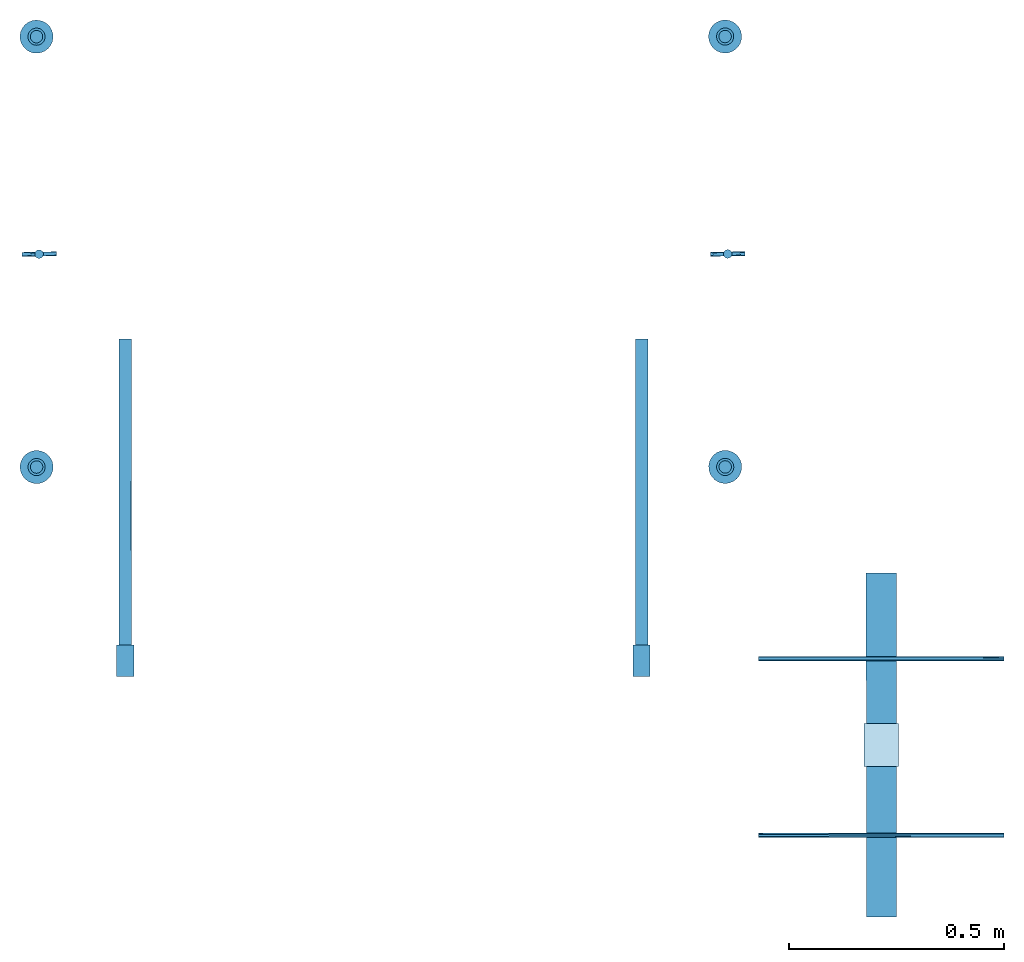
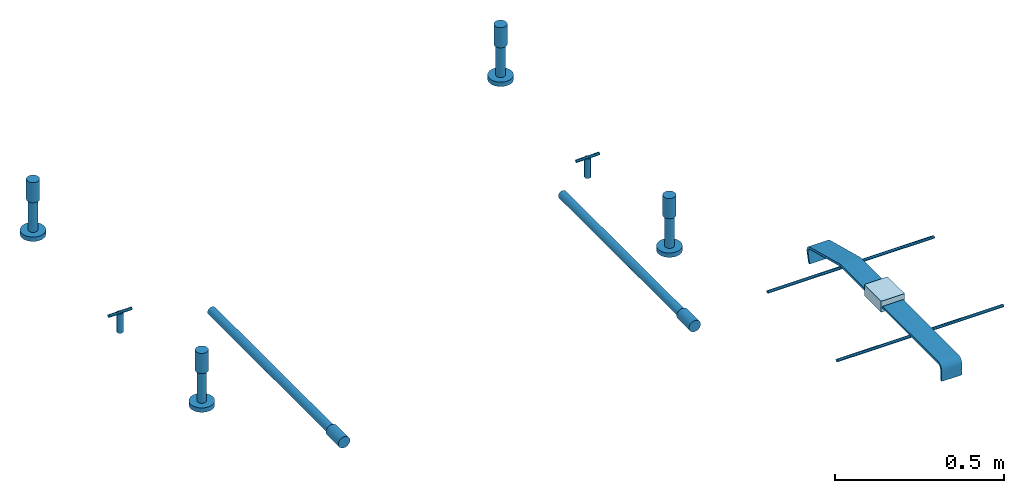
# One storey: 12 reinforcing bars, 6 columns, 4 discrete accessories, 2 beams, 1 plate, 9 elements without a shape of their own.
"""IFC2X3 building model written with IfcOpenShell, lengths in millimetres."""

from ifc_helpers import new_model, entity, si_unit, frame, frame_2d, origin_with_axes, origin_2d_with_axis, place, context, subcontext, project, spatial, polyline, circle_curve, parameter, trimmed, segment, composite_curve, circle, outline, extrude, source, transform, mapped, material, type_object, element, aggregate, save


model = new_model("IFC2X3")

# Units and contexts
model_context = context("Model", 3, precision=1e-05, world=origin_with_axes())
body_context = subcontext(model_context, "Body", "Model", "MODEL_VIEW")
ifc_project = project(units=[si_unit("LENGTHUNIT", "METRE", prefix="MILLI"), si_unit("AREAUNIT", "SQUARE_METRE"), si_unit("VOLUMEUNIT", "CUBIC_METRE"), si_unit("MASSUNIT", "GRAM", prefix="KILO"), si_unit("TIMEUNIT", "SECOND"), si_unit("PLANEANGLEUNIT", "RADIAN"), si_unit("SOLIDANGLEUNIT", "STERADIAN"), si_unit("THERMODYNAMICTEMPERATUREUNIT", "DEGREE_CELSIUS"), si_unit("LUMINOUSINTENSITYUNIT", "LUMEN")], contexts=[model_context])

# Site, building, storey
site_placement = place(None, origin_with_axes())
site = spatial("IfcSite", under=ifc_project, at=site_placement, CompositionType="ELEMENT")
building_placement = place(site_placement, origin_with_axes())
building = spatial("IfcBuilding", under=site, at=building_placement, Name="Undefined", CompositionType="ELEMENT")
storey_placement = place(building_placement, origin_with_axes())
storey = spatial("IfcBuildingStorey", under=building, at=storey_placement, Name="Undefined", CompositionType="ELEMENT", Elevation=0.0)

# Assembly, column
assembly_1_placement = place(storey_placement, origin_with_axes())
assembly_1 = element("IfcElementAssembly", 1, at=assembly_1_placement, inside=storey, Name="Steel Assembly", AssemblyPlace="NOTDEFINED", PredefinedType="RIGID_FRAME")
ifc_material_1 = material(Name="STEEL/Steel_Undefined")
column_type_1 = type_object("IfcColumnType", Name="D40", PredefinedType="NOTDEFINED")
column_1_placement = place(assembly_1_placement, frame((16512.5545735063, 4541.76865456294, 168.744955736245), z_axis=(0.0, 0.0, 1.0), x_axis=(-0.529843759894113, -0.848095271830512, 0.0)))
column_1 = element("IfcColumn", 2, at=column_1_placement, type_object=column_type_1, material=ifc_material_1, Name="PLA30", ObjectType="D40", context=body_context, shape_type="SweptSolid", body=[
    extrude(circle(Radius=20.0, at=origin_2d_with_axis()), frame((0.0, 0.0, 73.0000000000042), z_axis=(6.95326889399439e-11, -3.79999987217161e-07, -0.999999999999928), x_axis=(0.0, 1.0, 0.0)), (0.0, 0.0, 1.0), 73.0),
])

assembly_2_placement = place(storey_placement, origin_with_axes())
assembly_2 = element("IfcElementAssembly", 3, at=assembly_2_placement, inside=storey, Name="Steel Assembly", AssemblyPlace="NOTDEFINED", PredefinedType="RIGID_FRAME")
column_2_placement = place(assembly_2_placement, frame((16512.3715884973, 5541.76863781694, 180.406980387786), z_axis=(0.0, 0.0, 1.0), x_axis=(0.530154102006484, -0.847901308010371, 0.0)))
column_2 = element("IfcColumn", 4, at=column_2_placement, type_object=column_type_1, material=ifc_material_1, Name="PLA30", ObjectType="D40", context=body_context, shape_type="SweptSolid", body=[
    extrude(circle(Radius=20.0, at=origin_2d_with_axis()), frame((0.0, 0.0, 73.0000000000042), z_axis=(6.95326889399439e-11, -3.79999987217161e-07, -0.999999999999928), x_axis=(0.0, 1.0, 0.0)), (0.0, 0.0, 1.0), 73.0),
])

assembly_3_placement = place(storey_placement, origin_with_axes())
assembly_3 = element("IfcElementAssembly", 5, at=assembly_3_placement, inside=storey, Name="Steel Assembly", AssemblyPlace="NOTDEFINED", PredefinedType="RIGID_FRAME")
column_3_placement = place(assembly_3_placement, frame((14912.5546002998, 4541.47587857633, 168.744935248384), z_axis=(0.0, 0.0, 1.0), x_axis=(-0.530154102006485, 0.847901308010371, 0.0)))
column_3 = element("IfcColumn", 6, at=column_3_placement, type_object=column_type_1, material=ifc_material_1, Name="PLA30", ObjectType="D40", context=body_context, shape_type="SweptSolid", body=[
    extrude(circle(Radius=20.0, at=origin_2d_with_axis()), frame((0.0, 0.0, 73.0000000000042), z_axis=(6.95326889399439e-11, -3.79999987217161e-07, -0.999999999999928), x_axis=(0.0, 1.0, 0.0)), (0.0, 0.0, 1.0), 73.0),
])

assembly_4_placement = place(storey_placement, origin_with_axes())
assembly_4 = element("IfcElementAssembly", 7, at=assembly_4_placement, inside=storey, Name="Steel Assembly", AssemblyPlace="NOTDEFINED", PredefinedType="RIGID_FRAME")
column_4_placement = place(assembly_4_placement, frame((14912.3716152909, 5541.47586183033, 180.406959899928), z_axis=(0.0, 0.0, 1.0), x_axis=(0.529843759894112, 0.848095271830512, 0.0)))
column_4 = element("IfcColumn", 8, at=column_4_placement, type_object=column_type_1, material=ifc_material_1, Name="PLA30", ObjectType="D40", context=body_context, shape_type="SweptSolid", body=[
    extrude(circle(Radius=20.0, at=origin_2d_with_axis()), frame((0.0, 0.0, 73.0000000000042), z_axis=(6.95326889399439e-11, -3.79999987217161e-07, -0.999999999999928), x_axis=(0.0, 1.0, 0.0)), (0.0, 0.0, 1.0), 73.0),
])

assembly_5_placement = place(storey_placement, origin_with_axes())
assembly_5 = element("IfcElementAssembly", 9, at=assembly_5_placement, inside=storey, Name="Steel Assembly", AssemblyPlace="NOTDEFINED", PredefinedType="RIGID_FRAME")
ifc_material_2 = material(Name="STEEL/1.4305")
column_type_2 = type_object("IfcColumnType", Name="D20", PredefinedType="NOTDEFINED")
column_5_placement = place(assembly_5_placement, frame((14918.3528687996, 5036.27663697052, 4.99973108393383), z_axis=(0.0, 0.0, 1.0), x_axis=(-0.0185757400010389, 0.999827456056001, 0.0)))
column_5 = element("IfcColumn", 10, at=column_5_placement, type_object=column_type_2, material=ifc_material_2, Name="M16x70", ObjectType="D20", context=body_context, shape_type="SweptSolid", body=[
    extrude(circle(Radius=10.0, at=origin_2d_with_axis()), frame((0.0, 0.0, 70.0), z_axis=(6.95326889399439e-11, -3.79999987217161e-07, -0.999999999999928), x_axis=(0.0, 1.0, 0.0)), (0.0, 0.0, 1.0), 70.0),
])

assembly_6_placement = place(storey_placement, origin_with_axes())
assembly_6 = element("IfcElementAssembly", 11, at=assembly_6_placement, inside=storey, Name="Steel Assembly", AssemblyPlace="NOTDEFINED", PredefinedType="RIGID_FRAME")
column_6_placement = place(assembly_6_placement, frame((16518.352842022, 5036.5694137126, 4.99973107646505), z_axis=(0.0, 0.0, 1.0), x_axis=(-0.0185757400010389, 0.999827456056001, 0.0)))
column_6 = element("IfcColumn", 12, at=column_6_placement, type_object=column_type_2, material=ifc_material_2, Name="M16x70", ObjectType="D20", context=body_context, shape_type="SweptSolid", body=[
    extrude(circle(Radius=10.0, at=origin_2d_with_axis()), frame((0.0, 0.0, 70.0), z_axis=(6.95326889399439e-11, -3.79999987217161e-07, -0.999999999999928), x_axis=(0.0, 1.0, 0.0)), (0.0, 0.0, 1.0), 70.0),
])

# Assembly, beam
assembly_7_placement = place(storey_placement, origin_with_axes())
assembly_7 = element("IfcElementAssembly", 13, at=assembly_7_placement, inside=storey, Name="Steel Assembly", AssemblyPlace="NOTDEFINED", PredefinedType="RIGID_FRAME")
beam_type = type_object("IfcBeamType", Name="D40", PredefinedType="NOTDEFINED")
beam_1_placement = place(assembly_7_placement, frame((16318.3244750707, 4127.76566994442, 129.998808840351), z_axis=(-2.6939999552269e-06, 1.19564911619818e-06, 0.999999999995656), x_axis=(0.000130249999940337, -0.999999991516754, 1.19599999948291e-06)))
beam_1 = element("IfcBeam", 14, at=beam_1_placement, type_object=beam_type, material=ifc_material_1, Name="PLA30P RST", ObjectType="D40", context=body_context, shape_type="SweptSolid", body=[
    extrude(circle(Radius=20.0, at=origin_2d_with_axis()), frame((72.9999999999711, -1.81899029789767e-12, 0.0), z_axis=(-1.0, 1.22513946707428e-20, 0.0), x_axis=(1.20588191077635e-20, -1.0, -4.2351647362715e-22)), (0.0, 0.0, 1.0), 73.0),
])

assembly_8_placement = place(storey_placement, origin_with_axes())
assembly_8 = element("IfcElementAssembly", 15, at=assembly_8_placement, inside=storey, Name="Steel Assembly", AssemblyPlace="NOTDEFINED", PredefinedType="RIGID_FRAME")
beam_2_placement = place(assembly_8_placement, frame((15118.3244850687, 4127.60936877322, 129.995575973906), z_axis=(-2.6939999552269e-06, 1.19564911619818e-06, 0.999999999995656), x_axis=(0.000130249999940337, -0.999999991516754, 1.19599999948291e-06)))
beam_2 = element("IfcBeam", 16, at=beam_2_placement, type_object=beam_type, material=ifc_material_1, Name="PLA30P RST", ObjectType="D40", context=body_context, shape_type="SweptSolid", body=[
    extrude(circle(Radius=20.0, at=origin_2d_with_axis()), frame((72.9999999999711, -1.81899029789767e-12, 0.0), z_axis=(-1.0, 1.22513946707428e-20, 0.0), x_axis=(1.20588191077635e-20, -1.0, -4.2351647362715e-22)), (0.0, 0.0, 1.0), 73.0),
])

# Assembly, plate
assembly_9_placement = place(storey_placement, origin_with_axes())
assembly_9 = element("IfcElementAssembly", 17, at=assembly_9_placement, inside=storey, Name="Steel Assembly", AssemblyPlace="NOTDEFINED", PredefinedType="RIGID_FRAME")
plate_type = type_object("IfcPlateType", Name="PL80X40", PredefinedType="NOTDEFINED")
plate_placement = place(assembly_9_placement, frame((16875.2878480208, 3945.99448057464, 125.299789938123), z_axis=(0.999999983258245, 0.000182985000042784, -6.95343011720966e-11), x_axis=(0.0, 0.0, 1.0)))
plate = element("IfcPlate", 18, at=plate_placement, type_object=plate_type, material=ifc_material_1, Name="PS170", ObjectType="PL80X40", context=body_context, shape_type="SweptSolid", body=[
    extrude(outline(polyline([(0.0, 0.0), (40.0000000000003, -7.27595761418343e-12), (39.9999999999937, 99.9999999999027), (-6.60804744256893e-12, 99.9999999999091), (0.0, 0.0)])), frame((5.16987882845642e-25, -1.26000840385288e-18, -40.0), z_axis=(0.0, 0.0, 1.0), x_axis=(1.0, 0.0, 0.0)), (0.0, 0.0, 1.0), 80.0),
])

# Reinforcing bar
ifc_material_3 = material(Name="Undefined")
shared_shape_1 = source(origin_with_axes(), body_context, "Body", "AdvancedSweptSolid", [
    entity("IfcSweptDiskSolid", entity("IfcTrimmedCurve", entity("IfcLine", entity("IfcCartesianPoint", [0.0, 0.0, 0.0]), entity("IfcVector", entity("IfcDirection", [1.0, 0.0, 0.0]), 1.0)), [entity("IfcParameterValue", 0.0)], [entity("IfcParameterValue", 711.000000000277)], True, "PARAMETER"), 14.5, None, 0.0, 711.000000000277),
])
reinforcing_bar_1_placement = place(assembly_7_placement, frame((16318.3253064724, 4127.76567012168, 129.999346738555), z_axis=(0.999548757077827, 0.0001301553015237, -0.0300377310023403), x_axis=(-0.000130249999936652, 0.999999991516754, -1.1959999994261e-06)))
reinforcing_bar_1 = element("IfcReinforcingBar", 19, at=reinforcing_bar_1_placement, material=ifc_material_3, Name="REBAR", BarRole="NOTDEFINED", CrossSectionArea=0.0, NominalDiameter=29.0, context=body_context, shape_type="MappedRepresentation", body=[
    mapped(shared_shape_1, transform((0.0, 0.0, 0.0))),
])

aggregate(assembly_7, [beam_1, reinforcing_bar_1])

shared_shape_2 = source(origin_with_axes(), body_context, "Body", "AdvancedSweptSolid", [
    entity("IfcSweptDiskSolid", entity("IfcTrimmedCurve", entity("IfcLine", entity("IfcCartesianPoint", [0.0, 0.0, 0.0]), entity("IfcVector", entity("IfcDirection", [1.0, 0.0, 0.0]), 1.0)), [entity("IfcParameterValue", 0.0)], [entity("IfcParameterValue", 711.000000000276)], True, "PARAMETER"), 14.5, None, 0.0, 711.000000000276),
])
reinforcing_bar_2_placement = place(assembly_8_placement, frame((15118.3253164704, 4127.60936895047, 129.99611387211), z_axis=(0.999548757077827, 0.0001301553015237, -0.0300377310023403), x_axis=(-0.000130249999936652, 0.999999991516754, -1.1959999994261e-06)))
reinforcing_bar_2 = element("IfcReinforcingBar", 20, at=reinforcing_bar_2_placement, material=ifc_material_3, Name="REBAR", BarRole="NOTDEFINED", CrossSectionArea=0.0, NominalDiameter=29.0, context=body_context, shape_type="MappedRepresentation", body=[
    mapped(shared_shape_2, transform((0.0, 0.0, 0.0))),
])

aggregate(assembly_8, [beam_2, reinforcing_bar_2])

# Discrete accessory
discrete_accessory_type_1 = type_object("IfcDiscreteAccessoryType", Name="PS170")
discrete_accessory_1_placement = place(assembly_9_placement, frame((16875.304316671, 3855.99448968144, 145.299824138153), z_axis=(0.999999983258245, 0.000182985000042784, -6.95343011720966e-11), x_axis=(0.000182985000042797, -0.999999983258173, 3.80000000098684e-07)))
discrete_accessory_1 = element("IfcDiscreteAccessory", 21, at=discrete_accessory_1_placement, type_object=discrete_accessory_type_1, material=ifc_material_1, Name="PS170", ObjectType="PL70X60", context=body_context, shape_type="SweptSolid", body=[
    extrude(outline(composite_curve([segment(polyline([(0.0, 0.0), (336.99999999969, 1.24941203062511e-10)]), True, "CONTINUOUS"), segment(trimmed(circle_curve(frame_2d((336.999999999681, 23.0000000001249), x_axis=(3.70717949092226e-13, -1.0)), 23.0), [parameter(0.0)], [parameter(1.57079632679422)], True, "PARAMETER"), True, "CONTINUOUS"), segment(polyline([(359.999999999681, 23.0000000001179), (359.999999999693, 60.0000000001215), (351.999999999701, 60.0000000001187), (351.999999999689, 23.0000000001127)]), True, "CONTINUOUS"), segment(trimmed(circle_curve(frame_2d((336.999999999681, 23.0000000001249), x_axis=(1.0, 0.0)), 15.0), [parameter(0.0)], [parameter(4.71238898038535)], False, "PARAMETER"), True, "CONTINUOUS"), segment(polyline([(336.999999999694, 8.00000000011747), (2.27373675443232e-12, 7.9999999999994), (0.0, 0.0)]), True, "CONTINUOUS")], self_intersect=True)), frame((-1.10244947356844e-18, -4.52364397489937e-25, -35.0), z_axis=(0.0, 0.0, 1.0), x_axis=(1.0, 0.0, 0.0)), (0.0, 0.0, 1.0), 70.0),
])

discrete_accessory_2_placement = place(assembly_9_placement, frame((16875.2228883451, 4300.99446284437, 91.7996006227985), z_axis=(0.999999983258245, 0.000182985000042784, -6.95343011720966e-11), x_axis=(0.000177055000000519, -0.967592137991381, 0.252518163997751)))
discrete_accessory_2 = element("IfcDiscreteAccessory", 22, at=discrete_accessory_2_placement, type_object=discrete_accessory_type_1, material=ifc_material_1, Name="PS170", ObjectType="PL70X111", context=body_context, shape_type="SweptSolid", body=[
    extrude(outline(composite_curve([segment(trimmed(circle_curve(frame_2d((23.135112778959, 23.0000000000103), x_axis=(-0.99998284637346, 0.00585721425540805)), 23.0), [parameter(0.0)], [parameter(1.5766535745418)], True, "PARAMETER"), True, "CONTINUOUS"), segment(polyline([(23.1351127789693, 1.03038229540696e-11), (211.866119384571, 9.43600753089413e-11), (366.680877685222, 40.4028587342459), (364.610229491866, 48.3371124268738), (209.795471191217, 7.93425464636425), (22.606389052489, 8.00122769767903)]), True, "CONTINUOUS"), segment(trimmed(circle_curve(frame_2d((22.611755795538, 23.0012267376146), x_axis=(-0.000357782869936804, -0.999999935995707)), 15.0), [parameter(0.0)], [parameter(4.69316628351507)], False, "PARAMETER"), True, "CONTINUOUS"), segment(polyline([(7.61463116757275, 23.294915166528), (8.33238506317593, 59.9468345642226), (0.351640313876487, 60.0343894958605), (0.135507312369449, 23.1347159278847)]), True, "CONTINUOUS")], self_intersect=True)), frame((-1.10244947356844e-18, -4.52364397489937e-25, -35.0), z_axis=(0.0, 0.0, 1.0), x_axis=(1.0, 0.0, 0.0)), (0.0, 0.0, 1.0), 70.0),
])

# Reinforcing bar
shared_shape_3 = source(origin_with_axes(), body_context, "Body", "AdvancedSweptSolid", [
    entity("IfcSweptDiskSolid", entity("IfcTrimmedCurve", entity("IfcLine", entity("IfcCartesianPoint", [0.0, 0.0, 0.0]), entity("IfcVector", entity("IfcDirection", [1.0, 0.0, 0.0]), 1.0)), [entity("IfcParameterValue", 0.0)], [entity("IfcParameterValue", 569.999999999873)], True, "PARAMETER"), 5.0, None, 0.0, 569.999999999873),
])
reinforcing_bar_3_placement = place(assembly_9_placement, frame((16840.3354252976, 3685.98485693224, 133.299888741877), z_axis=(6.95326889399439e-11, -3.79999987217161e-07, -0.999999999999928), x_axis=(0.999999983258245, 0.000182985000042784, -6.95343011720966e-11)))
reinforcing_bar_3 = element("IfcReinforcingBar", 23, at=reinforcing_bar_3_placement, material=ifc_material_3, Name="REBAR", BarRole="NOTDEFINED", CrossSectionArea=0.0, NominalDiameter=10.0, context=body_context, shape_type="MappedRepresentation", body=[
    mapped(shared_shape_3, transform((-249.999999999945, 5.41149347554892e-11, -5.6843418860808e-14))),
])

shared_shape_4 = source(origin_with_axes(), body_context, "Body", "AdvancedSweptSolid", [
    entity("IfcSweptDiskSolid", entity("IfcTrimmedCurve", entity("IfcLine", entity("IfcCartesianPoint", [0.0, 0.0, 0.0]), entity("IfcVector", entity("IfcDirection", [1.0, 0.0, 0.0]), 1.0)), [entity("IfcParameterValue", 0.0)], [entity("IfcParameterValue", 569.999999999876)], True, "PARAMETER"), 5.0, None, 0.0, 569.999999999876),
])
reinforcing_bar_4_placement = place(assembly_9_placement, frame((16840.2604008594, 4095.9880613081, 133.099628772188), z_axis=(6.95326889399439e-11, -3.79999987217161e-07, -0.999999999999928), x_axis=(0.999999983258245, 0.000182985000042784, -6.95343011720966e-11)))
reinforcing_bar_4 = element("IfcReinforcingBar", 24, at=reinforcing_bar_4_placement, material=ifc_material_3, Name="REBAR", BarRole="NOTDEFINED", CrossSectionArea=0.0, NominalDiameter=10.0, context=body_context, shape_type="MappedRepresentation", body=[
    mapped(shared_shape_4, transform((-249.999999999945, 5.41149347554892e-11, -5.6843418860808e-14))),
])

aggregate(assembly_9, [discrete_accessory_1, reinforcing_bar_3, discrete_accessory_2, reinforcing_bar_4, plate])

shared_shape_5 = source(origin_with_axes(), body_context, "Body", "AdvancedSweptSolid", [
    entity("IfcSweptDiskSolid", entity("IfcTrimmedCurve", entity("IfcLine", entity("IfcCartesianPoint", [0.0, 0.0, 0.0]), entity("IfcVector", entity("IfcDirection", [1.0, 0.0, 0.0]), 1.0)), [entity("IfcParameterValue", 0.0)], [entity("IfcParameterValue", 111.0)], True, "PARAMETER"), 14.5, None, 0.0, 111.0),
])
reinforcing_bar_5_placement = place(assembly_1_placement, frame((16512.5545735063, 4541.76865456294, 168.744955736245), z_axis=(0.848095271830512, -0.529843759894113, 0.0), x_axis=(6.95326889399439e-11, -3.79999987217161e-07, -0.999999999999928)))
reinforcing_bar_5 = element("IfcReinforcingBar", 25, at=reinforcing_bar_5_placement, material=ifc_material_3, Name="REBAR", BarRole="NOTDEFINED", CrossSectionArea=0.0, NominalDiameter=29.0, context=body_context, shape_type="MappedRepresentation", body=[
    mapped(shared_shape_5, transform((0.0, 0.0, 0.0))),
])

shared_shape_6 = source(origin_with_axes(), body_context, "Body", "AdvancedSweptSolid", [
    entity("IfcSweptDiskSolid", entity("IfcTrimmedCurve", entity("IfcLine", entity("IfcCartesianPoint", [0.0, 0.0, 0.0]), entity("IfcVector", entity("IfcDirection", [1.0, 0.0, 0.0]), 1.0)), [entity("IfcParameterValue", 0.0)], [entity("IfcParameterValue", 16.0)], True, "PARAMETER"), 38.5, None, 0.0, 16.0),
])
reinforcing_bar_6_placement = place(assembly_1_placement, frame((16512.5545735091, 4541.76865456303, 41.7449557362435), z_axis=(-0.848095271830512, 0.529843759894112, 0.0), x_axis=(0.0, 0.0, 1.0)))
reinforcing_bar_6 = element("IfcReinforcingBar", 26, at=reinforcing_bar_6_placement, material=ifc_material_3, Name="REBAR", BarRole="NOTDEFINED", CrossSectionArea=0.0, NominalDiameter=77.0, context=body_context, shape_type="MappedRepresentation", body=[
    mapped(shared_shape_6, transform((0.0, 0.0, 0.0))),
])

aggregate(assembly_1, [column_1, reinforcing_bar_5, reinforcing_bar_6])

shared_shape_7 = source(origin_with_axes(), body_context, "Body", "AdvancedSweptSolid", [
    entity("IfcSweptDiskSolid", entity("IfcTrimmedCurve", entity("IfcLine", entity("IfcCartesianPoint", [0.0, 0.0, 0.0]), entity("IfcVector", entity("IfcDirection", [1.0, 0.0, 0.0]), 1.0)), [entity("IfcParameterValue", 0.0)], [entity("IfcParameterValue", 111.0)], True, "PARAMETER"), 14.5, None, 0.0, 111.0),
])
reinforcing_bar_7_placement = place(assembly_2_placement, frame((16512.3715884973, 5541.76863781694, 180.406980387786), z_axis=(0.847901308010371, 0.530154102006484, 0.0), x_axis=(6.95326889399439e-11, -3.79999987217161e-07, -0.999999999999928)))
reinforcing_bar_7 = element("IfcReinforcingBar", 27, at=reinforcing_bar_7_placement, material=ifc_material_3, Name="REBAR", BarRole="NOTDEFINED", CrossSectionArea=0.0, NominalDiameter=29.0, context=body_context, shape_type="MappedRepresentation", body=[
    mapped(shared_shape_7, transform((0.0, 0.0, 0.0))),
])

shared_shape_8 = source(origin_with_axes(), body_context, "Body", "AdvancedSweptSolid", [
    entity("IfcSweptDiskSolid", entity("IfcTrimmedCurve", entity("IfcLine", entity("IfcCartesianPoint", [0.0, 0.0, 0.0]), entity("IfcVector", entity("IfcDirection", [1.0, 0.0, 0.0]), 1.0)), [entity("IfcParameterValue", 0.0)], [entity("IfcParameterValue", 16.0)], True, "PARAMETER"), 38.5, None, 0.0, 16.0),
])
reinforcing_bar_8_placement = place(assembly_2_placement, frame((16512.3715885024, 5541.76863782199, 53.4069803877829), z_axis=(-0.847901308010371, -0.530154102006485, 0.0), x_axis=(0.0, 0.0, 1.0)))
reinforcing_bar_8 = element("IfcReinforcingBar", 28, at=reinforcing_bar_8_placement, material=ifc_material_3, Name="REBAR", BarRole="NOTDEFINED", CrossSectionArea=0.0, NominalDiameter=77.0, context=body_context, shape_type="MappedRepresentation", body=[
    mapped(shared_shape_8, transform((0.0, 0.0, 0.0))),
])

aggregate(assembly_2, [column_2, reinforcing_bar_7, reinforcing_bar_8])

shared_shape_9 = source(origin_with_axes(), body_context, "Body", "AdvancedSweptSolid", [
    entity("IfcSweptDiskSolid", entity("IfcTrimmedCurve", entity("IfcLine", entity("IfcCartesianPoint", [0.0, 0.0, 0.0]), entity("IfcVector", entity("IfcDirection", [1.0, 0.0, 0.0]), 1.0)), [entity("IfcParameterValue", 0.0)], [entity("IfcParameterValue", 111.0)], True, "PARAMETER"), 14.5, None, 0.0, 111.0),
])
reinforcing_bar_9_placement = place(assembly_3_placement, frame((14912.5546002998, 4541.47587857633, 168.744935248384), z_axis=(-0.847901308010371, -0.530154102006485, 0.0), x_axis=(6.95326889399439e-11, -3.79999987217161e-07, -0.999999999999928)))
reinforcing_bar_9 = element("IfcReinforcingBar", 29, at=reinforcing_bar_9_placement, material=ifc_material_3, Name="REBAR", BarRole="NOTDEFINED", CrossSectionArea=0.0, NominalDiameter=29.0, context=body_context, shape_type="MappedRepresentation", body=[
    mapped(shared_shape_9, transform((0.0, 0.0, 0.0))),
])

shared_shape_10 = source(origin_with_axes(), body_context, "Body", "AdvancedSweptSolid", [
    entity("IfcSweptDiskSolid", entity("IfcTrimmedCurve", entity("IfcLine", entity("IfcCartesianPoint", [0.0, 0.0, 0.0]), entity("IfcVector", entity("IfcDirection", [1.0, 0.0, 0.0]), 1.0)), [entity("IfcParameterValue", 0.0)], [entity("IfcParameterValue", 16.0)], True, "PARAMETER"), 38.5, None, 0.0, 16.0),
])
reinforcing_bar_10_placement = place(assembly_3_placement, frame((14912.5546002948, 4541.47587857127, 41.7449352483819), z_axis=(0.847901308010371, 0.530154102006484, 0.0), x_axis=(0.0, 0.0, 1.0)))
reinforcing_bar_10 = element("IfcReinforcingBar", 30, at=reinforcing_bar_10_placement, material=ifc_material_3, Name="REBAR", BarRole="NOTDEFINED", CrossSectionArea=0.0, NominalDiameter=77.0, context=body_context, shape_type="MappedRepresentation", body=[
    mapped(shared_shape_10, transform((0.0, 0.0, 0.0))),
])

aggregate(assembly_3, [column_3, reinforcing_bar_9, reinforcing_bar_10])

shared_shape_11 = source(origin_with_axes(), body_context, "Body", "AdvancedSweptSolid", [
    entity("IfcSweptDiskSolid", entity("IfcTrimmedCurve", entity("IfcLine", entity("IfcCartesianPoint", [0.0, 0.0, 0.0]), entity("IfcVector", entity("IfcDirection", [1.0, 0.0, 0.0]), 1.0)), [entity("IfcParameterValue", 0.0)], [entity("IfcParameterValue", 111.0)], True, "PARAMETER"), 14.5, None, 0.0, 111.0),
])
reinforcing_bar_11_placement = place(assembly_4_placement, frame((14912.3716152909, 5541.47586183033, 180.406959899928), z_axis=(-0.848095271830512, 0.529843759894112, 0.0), x_axis=(6.95326889399439e-11, -3.79999987217161e-07, -0.999999999999928)))
reinforcing_bar_11 = element("IfcReinforcingBar", 31, at=reinforcing_bar_11_placement, material=ifc_material_3, Name="REBAR", BarRole="NOTDEFINED", CrossSectionArea=0.0, NominalDiameter=29.0, context=body_context, shape_type="MappedRepresentation", body=[
    mapped(shared_shape_11, transform((0.0, 0.0, 0.0))),
])

shared_shape_12 = source(origin_with_axes(), body_context, "Body", "AdvancedSweptSolid", [
    entity("IfcSweptDiskSolid", entity("IfcTrimmedCurve", entity("IfcLine", entity("IfcCartesianPoint", [0.0, 0.0, 0.0]), entity("IfcVector", entity("IfcDirection", [1.0, 0.0, 0.0]), 1.0)), [entity("IfcParameterValue", 0.0)], [entity("IfcParameterValue", 16.0)], True, "PARAMETER"), 38.5, None, 0.0, 16.0),
])
reinforcing_bar_12_placement = place(assembly_4_placement, frame((14912.3716152881, 5541.47586183023, 53.406959899925), z_axis=(0.848095271830512, -0.529843759894113, 0.0), x_axis=(0.0, 0.0, 1.0)))
reinforcing_bar_12 = element("IfcReinforcingBar", 32, at=reinforcing_bar_12_placement, material=ifc_material_3, Name="REBAR", BarRole="NOTDEFINED", CrossSectionArea=0.0, NominalDiameter=77.0, context=body_context, shape_type="MappedRepresentation", body=[
    mapped(shared_shape_12, transform((0.0, 0.0, 0.0))),
])

aggregate(assembly_4, [column_4, reinforcing_bar_11, reinforcing_bar_12])

# Discrete accessory
discrete_accessory_type_2 = type_object("IfcDiscreteAccessoryType", Name="DUMMY")
discrete_accessory_3_placement = place(assembly_5_placement, frame((14958.3459670413, 5037.01966656577, 74.9997310844736), z_axis=(-0.0185757400010389, 0.999827456056001, 0.0), x_axis=(-0.999827456056001, -0.0185757400010381, 0.0)))
discrete_accessory_3 = element("IfcDiscreteAccessory", 33, at=discrete_accessory_3_placement, type_object=discrete_accessory_type_2, material=ifc_material_2, Name="DUMMY", ObjectType="D10", context=body_context, shape_type="SweptSolid", body=[
    extrude(circle(Radius=5.0, at=origin_2d_with_axis()), frame((80.0000000005588, -1.4210854715202e-14, 0.0), z_axis=(-1.0, 1.22513946707428e-20, 0.0), x_axis=(1.20588191077635e-20, -1.0, -4.2351647362715e-22)), (0.0, 0.0, 1.0), 80.0),
])

aggregate(assembly_5, [discrete_accessory_3, column_5])

discrete_accessory_4_placement = place(assembly_6_placement, frame((16558.3459402637, 5037.31244330814, 74.9997310768991), z_axis=(-0.0185757400010389, 0.999827456056001, 0.0), x_axis=(-0.999827456056001, -0.0185757400010381, 0.0)))
discrete_accessory_4 = element("IfcDiscreteAccessory", 34, at=discrete_accessory_4_placement, type_object=discrete_accessory_type_2, material=ifc_material_2, Name="DUMMY", ObjectType="D10", context=body_context, shape_type="SweptSolid", body=[
    extrude(circle(Radius=5.0, at=origin_2d_with_axis()), frame((80.0000000005588, -1.4210854715202e-14, 0.0), z_axis=(-1.0, 1.22513946707428e-20, 0.0), x_axis=(1.20588191077635e-20, -1.0, -4.2351647362715e-22)), (0.0, 0.0, 1.0), 80.0),
])

aggregate(assembly_6, [discrete_accessory_4, column_6])

save(model, "model.ifc")
